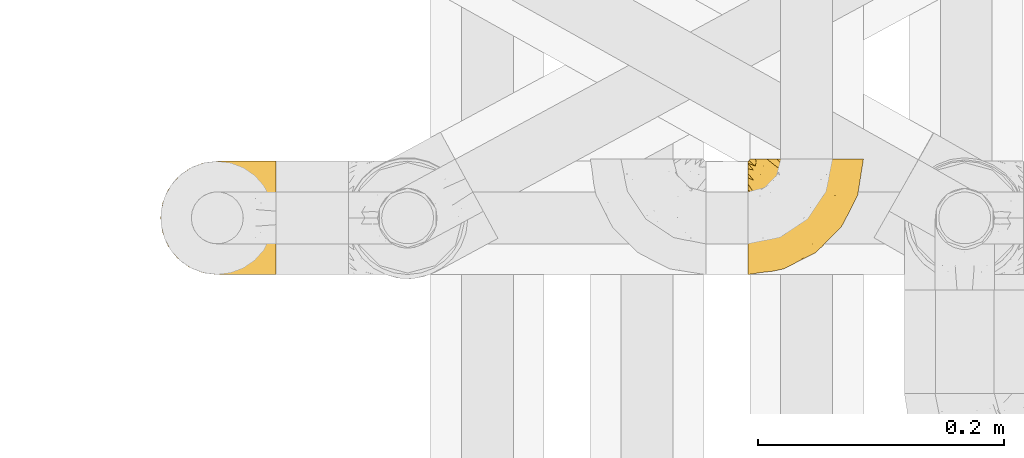
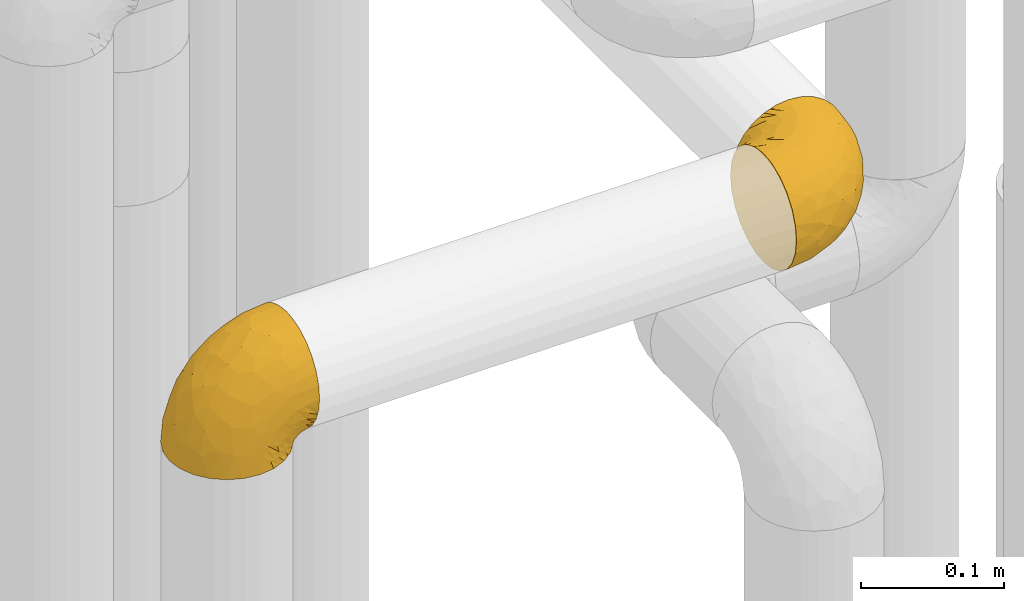
# One storey, part 158 of 827: 2 coverings.
"""IFC2X3 building model written with IfcOpenShell, lengths in millimetres."""

from ifc_helpers import new_model, entity, si_unit, converted_unit, derived_unit, direction, frame, origin, place, context, subcontext, project, spatial, faceted_brep, element, save


model = new_model("IFC2X3")

# Units and contexts
model_context = context("Model", 3, precision=0.01, world=origin(), true_north=direction((6.12303176911189e-17, 1.0)))
body_context = subcontext(model_context, "Body", "Model", "MODEL_VIEW")
ifc_project = project(units=[si_unit("LENGTHUNIT", "METRE", prefix="MILLI"), si_unit("AREAUNIT", "SQUARE_METRE"), si_unit("VOLUMEUNIT", "CUBIC_METRE"), converted_unit("PLANEANGLEUNIT", "DEGREE", entity("IfcRatioMeasure", 0.0174532925199433), si_unit("PLANEANGLEUNIT", "RADIAN"), dimensions=[0, 0, 0, 0, 0, 0, 0]), si_unit("MASSUNIT", "GRAM", prefix="KILO"), derived_unit("MASSDENSITYUNIT", [(si_unit("MASSUNIT", "GRAM", prefix="KILO"), 1), (si_unit("LENGTHUNIT", "METRE"), -3)]), derived_unit("MOMENTOFINERTIAUNIT", [(si_unit("LENGTHUNIT", "METRE"), 4)]), si_unit("TIMEUNIT", "SECOND"), si_unit("FREQUENCYUNIT", "HERTZ"), si_unit("THERMODYNAMICTEMPERATUREUNIT", "DEGREE_CELSIUS"), derived_unit("THERMALTRANSMITTANCEUNIT", [(si_unit("MASSUNIT", "GRAM", prefix="KILO"), 1), (si_unit("THERMODYNAMICTEMPERATUREUNIT", "KELVIN"), -1), (si_unit("TIMEUNIT", "SECOND"), -3)]), derived_unit("VOLUMETRICFLOWRATEUNIT", [(si_unit("LENGTHUNIT", "METRE"), 3), (si_unit("TIMEUNIT", "SECOND"), -1)]), derived_unit("MASSFLOWRATEUNIT", [(si_unit("MASSUNIT", "GRAM", prefix="KILO"), 1), (si_unit("TIMEUNIT", "SECOND"), -1)]), derived_unit("ROTATIONALFREQUENCYUNIT", [(si_unit("TIMEUNIT", "SECOND"), -1)]), si_unit("ELECTRICCURRENTUNIT", "AMPERE"), si_unit("ELECTRICVOLTAGEUNIT", "VOLT"), si_unit("POWERUNIT", "WATT"), si_unit("FORCEUNIT", "NEWTON", prefix="KILO"), si_unit("ILLUMINANCEUNIT", "LUX"), si_unit("LUMINOUSFLUXUNIT", "LUMEN"), si_unit("LUMINOUSINTENSITYUNIT", "CANDELA"), derived_unit("USERDEFINED", [(si_unit("MASSUNIT", "GRAM", prefix="KILO"), -1), (si_unit("LENGTHUNIT", "METRE"), -2), (si_unit("TIMEUNIT", "SECOND"), 3), (si_unit("LUMINOUSFLUXUNIT", "LUMEN"), 1)]), derived_unit("LINEARVELOCITYUNIT", [(si_unit("LENGTHUNIT", "METRE"), 1), (si_unit("TIMEUNIT", "SECOND"), -1)]), si_unit("PRESSUREUNIT", "PASCAL"), derived_unit("USERDEFINED", [(si_unit("LENGTHUNIT", "METRE"), -2), (si_unit("MASSUNIT", "GRAM", prefix="KILO"), 1), (si_unit("TIMEUNIT", "SECOND"), -2)]), derived_unit("LINEARFORCEUNIT", [(si_unit("MASSUNIT", "GRAM", prefix="KILO"), 1), (si_unit("LENGTHUNIT", "METRE"), 1), (si_unit("TIMEUNIT", "SECOND"), -2), (si_unit("LENGTHUNIT", "METRE"), -1)]), derived_unit("PLANARFORCEUNIT", [(si_unit("MASSUNIT", "GRAM", prefix="KILO"), 1), (si_unit("LENGTHUNIT", "METRE"), 1), (si_unit("TIMEUNIT", "SECOND"), -2), (si_unit("LENGTHUNIT", "METRE"), -2)])], contexts=[model_context])

# Site, building, storey
site_placement = place(None, origin())
site = spatial("IfcSite", under=ifc_project, at=site_placement, CompositionType="ELEMENT")
building_placement = place(site_placement, origin())
building = spatial("IfcBuilding", under=site, at=building_placement, CompositionType="ELEMENT")
storey_placement = place(building_placement, frame((0.0, 0.0, 28200.0)))
storey = spatial("IfcBuildingStorey", under=building, at=storey_placement, Name="08", CompositionType="ELEMENT", Elevation=28200.0)

# Coverings
covering_1_placement = place(storey_placement, frame((35550.49, 11508.39, 2952.2)))
element("IfcCovering", 1, at=covering_1_placement, inside=storey, Name=":ADSK_", ObjectType=":ADSK_", PredefinedType="INSULATION", context=body_context, shape_type="Brep", body=[
    faceted_brep([(59.89, 95.8, 92.84), (69.65, 95.8, 89.42), (78.41, 95.8, 83.91), (85.73, 95.8, 76.59), (91.23, 95.8, 67.83), (94.64, 95.8, 58.07), (95.8, 95.8, 47.8), (94.64, 95.8, 37.51), (91.22, 95.8, 27.74), (85.72, 95.8, 18.98), (78.4, 95.8, 11.67), (69.64, 95.8, 6.17), (59.87, 95.8, 2.75), (49.6, 95.8, 1.6), (45.46, 95.8, 2.06), (42.39, 95.8, 2.41), (39.31, 95.8, 2.75), (34.43, 95.8, 4.46), (29.55, 95.8, 6.17), (25.17, 95.8, 8.93), (20.79, 95.8, 11.68), (17.13, 95.8, 15.34), (13.47, 95.8, 19.0), (7.97, 95.8, 27.76), (6.26, 95.8, 32.64), (4.56, 95.8, 37.52), (3.4, 95.8, 47.8), (4.56, 95.8, 58.08), (6.27, 95.8, 62.96), (7.98, 95.8, 67.85), (13.49, 95.8, 76.61), (17.14, 95.8, 80.26), (20.8, 95.8, 83.92), (25.18, 95.8, 86.67), (29.56, 95.8, 89.42), (34.44, 95.8, 91.13), (39.33, 95.8, 92.84), (42.39, 95.8, 93.18), (45.46, 95.8, 93.53), (49.6, 95.8, 94.0), (1.6, 94.0, 47.8), (1.6, 92.42, 35.84), (1.6, 87.81, 24.7), (1.6, 84.13, 19.91), (1.6, 80.46, 15.13), (1.6, 75.68, 11.46), (1.6, 70.9, 7.78), (1.6, 65.32, 5.48), (1.6, 59.75, 3.17), (1.6, 56.14, 2.69), (1.6, 54.05, 2.42), (1.6, 51.97, 2.14), (1.6, 47.8, 1.6), (1.6, 35.84, 3.17), (1.6, 24.7, 7.78), (1.6, 15.13, 15.13), (1.6, 7.78, 24.7), (1.6, 3.17, 35.84), (1.6, 1.6, 47.8), (1.6, 3.17, 59.75), (1.6, 7.78, 70.9), (1.6, 15.13, 80.46), (1.6, 24.7, 87.81), (1.6, 35.84, 92.42), (1.6, 47.8, 94.0), (1.6, 51.97, 93.45), (1.6, 56.14, 92.9), (1.6, 59.75, 92.42), (1.6, 65.32, 90.11), (1.6, 70.9, 87.81), (1.6, 75.68, 84.13), (1.6, 80.46, 80.46), (1.6, 84.13, 75.68), (1.6, 87.81, 70.9), (1.6, 92.42, 59.75), (36.81, 15.84, 71.98), (23.28, 6.99, 63.6), (45.8, 14.39, 59.72), (30.71, 6.2, 47.8), (21.2, 4.26, 55.16), (12.96, 3.39, 47.8), (66.2, 31.2, 63.76), (54.52, 26.47, 72.22), (17.98, 11.44, 74.18), (36.69, 47.65, 92.52), (35.54, 61.85, 94.0), (31.65, 59.25, 94.0), (27.75, 56.65, 94.0), (23.86, 54.05, 94.0), (19.97, 51.45, 94.0), (22.8, 19.8, 82.14), (42.68, 26.22, 80.34), (33.22, 31.58, 87.52), (59.45, 38.36, 79.59), (71.51, 51.54, 78.25), (62.67, 51.6, 85.01), (54.51, 55.97, 90.25), (47.57, 62.88, 93.2), (48.82, 41.35, 87.23), (74.99, 82.24, 85.55), (18.7, 40.88, 93.0), (15.75, 29.0, 89.31), (91.18, 74.06, 61.31), (85.28, 54.53, 56.86), (82.58, 57.97, 68.34), (75.78, 43.81, 65.71), (74.99, 38.22, 56.99), (67.27, 38.33, 72.15), (87.38, 74.76, 70.34), (82.04, 76.85, 78.36), (94.0, 84.43, 47.8), (77.81, 40.42, 47.8), (67.39, 30.0, 47.8), (56.21, 78.67, 93.06), (48.86, 92.06, 94.0), (48.11, 88.32, 94.0), (47.57, 85.6, 94.0), (47.03, 82.88, 94.0), (46.49, 80.15, 94.0), (45.95, 77.43, 94.0), (65.79, 76.36, 89.88), (17.24, 50.91, 94.0), (14.52, 50.36, 94.0), (11.79, 49.82, 94.0), (9.07, 49.28, 94.0), (7.2, 48.91, 94.0), (5.33, 48.54, 94.0), (91.19, 66.68, 47.8), (43.34, 73.53, 94.0), (40.74, 69.64, 94.0), (38.14, 65.75, 94.0), (72.73, 66.13, 83.7), (56.97, 19.58, 47.8), (62.23, 24.64, 55.9), (84.5, 53.55, 47.8), (43.84, 12.89, 47.8), (12.05, 82.81, 81.75), (18.95, 81.22, 86.43), (13.02, 86.57, 79.8), (8.34, 92.75, 69.84), (14.63, 89.68, 79.5), (11.09, 72.26, 88.08), (13.66, 64.73, 91.6), (20.08, 62.45, 92.93), (9.62, 60.63, 92.43), (9.48, 56.91, 93.24), (16.1, 58.14, 93.36), (3.43, 93.7, 57.25), (26.63, 83.4, 89.41), (33.72, 75.54, 92.89), (34.77, 79.46, 92.66), (6.75, 82.28, 79.58), (13.32, 76.25, 86.51), (19.95, 90.18, 83.91), (27.05, 87.92, 88.76), (6.05, 86.94, 73.94), (8.67, 65.12, 90.94), (26.11, 71.71, 91.94), (29.3, 75.21, 91.98), (6.33, 78.6, 82.79), (39.92, 87.27, 93.16), (34.41, 86.1, 91.89), (2.87, 94.52, 47.8), (20.93, 66.23, 92.22), (21.12, 84.69, 86.29), (27.43, 91.08, 88.56), (7.54, 71.77, 87.72), (18.46, 76.21, 88.33), (23.88, 68.58, 92.18), (7.78, 89.94, 71.78), (26.09, 71.7, 3.66), (18.44, 76.22, 7.27), (18.94, 81.22, 9.17), (9.07, 49.28, 1.6), (5.33, 48.54, 1.6), (14.52, 50.36, 1.6), (11.79, 49.82, 1.6), (3.42, 93.7, 38.35), (7.77, 89.95, 23.83), (47.03, 82.88, 1.6), (47.57, 85.6, 1.6), (48.86, 92.06, 1.6), (48.11, 88.32, 1.6), (14.62, 89.68, 16.1), (27.03, 87.92, 6.84), (20.08, 62.45, 2.66), (20.92, 66.23, 3.37), (27.75, 56.65, 1.6), (31.65, 59.25, 1.6), (6.33, 78.6, 12.8), (9.62, 60.63, 3.16), (9.48, 56.91, 2.35), (8.34, 92.76, 25.77), (13.3, 76.25, 9.09), (6.75, 82.28, 16.02), (12.04, 82.81, 13.85), (23.86, 54.05, 1.6), (19.97, 51.45, 1.6), (16.1, 58.14, 2.23), (19.94, 90.18, 11.69), (21.1, 84.7, 9.31), (39.93, 87.25, 2.43), (33.68, 75.58, 2.71), (29.29, 75.2, 3.61), (26.62, 83.39, 6.18), (27.88, 90.73, 6.77), (34.76, 79.47, 2.93), (6.05, 86.94, 21.66), (38.14, 65.75, 1.6), (12.8, 86.75, 16.09), (34.42, 86.08, 3.7), (45.95, 77.43, 1.6), (43.34, 73.53, 1.6), (40.74, 69.64, 1.6), (13.66, 64.73, 3.99), (17.24, 50.91, 1.6), (8.67, 65.12, 4.65), (11.09, 72.26, 7.51), (35.54, 61.85, 1.6), (23.84, 68.61, 3.43), (6.03, 74.03, 9.46), (46.49, 80.15, 1.6), (34.53, 49.81, 2.4), (21.2, 4.26, 40.43), (23.82, 19.95, 13.57), (41.32, 30.61, 11.3), (47.63, 25.71, 18.65), (52.66, 22.43, 27.26), (36.82, 15.84, 23.61), (49.75, 60.69, 3.07), (19.08, 40.49, 2.69), (45.8, 14.39, 35.87), (23.28, 6.99, 31.99), (21.36, 29.56, 6.71), (17.98, 11.44, 21.41), (82.58, 57.98, 27.24), (91.17, 74.06, 34.26), (85.27, 54.52, 38.73), (73.89, 43.47, 26.97), (66.2, 31.2, 31.83), (62.43, 33.27, 23.4), (63.54, 64.26, 6.91), (58.46, 74.29, 3.4), (67.17, 80.41, 5.84), (76.73, 41.67, 35.73), (62.23, 24.64, 39.69), (81.54, 73.62, 17.6), (74.8, 78.98, 10.38), (75.84, 53.69, 20.6), (41.45, 42.86, 5.36), (88.21, 79.66, 24.84), (71.61, 58.41, 13.87), (56.24, 47.11, 9.06), (59.45, 38.37, 15.99)], [[[0, 1, 2, 3, 4, 5, 6, 7, 8, 9, 10, 11, 12, 13, 14, 15, 16, 17, 18, 19, 20, 21, 22, 23, 24, 25, 26, 27, 28, 29, 30, 31, 32, 33, 34, 35, 36, 37, 38, 39]], [[40, 41, 42, 43, 44, 45, 46, 47, 48, 49, 50, 51, 52, 53, 54, 55, 56, 57, 58, 59, 60, 61, 62, 63, 64, 65, 66, 67, 68, 69, 70, 71, 72, 73, 74]], [[75, 76, 77]], [[78, 79, 80]], [[77, 81, 82]], [[76, 75, 83]], [[84, 85, 86, 87, 88, 89]], [[90, 91, 92]], [[76, 60, 59]], [[93, 94, 95]], [[90, 62, 61]], [[83, 61, 60]], [[96, 97, 84]], [[98, 93, 95]], [[2, 1, 99]], [[100, 84, 89]], [[62, 101, 63]], [[4, 102, 5]], [[92, 84, 100]], [[103, 102, 104]], [[103, 105, 106]], [[93, 107, 94]], [[3, 108, 4]], [[92, 101, 90]], [[108, 3, 109]], [[102, 110, 5]], [[93, 82, 107]], [[102, 108, 104]], [[111, 106, 112]], [[109, 2, 99]], [[113, 39, 114, 115, 116, 117, 118, 119]], [[120, 0, 113]], [[100, 89, 121, 122, 123, 124, 125, 126, 64]], [[127, 102, 103]], [[97, 119, 128, 129, 130, 85]], [[99, 120, 131]], [[132, 133, 77]], [[59, 80, 79]], [[3, 2, 109]], [[98, 84, 92]], [[94, 109, 131]], [[120, 1, 0]], [[93, 91, 82]], [[104, 94, 105]], [[97, 113, 119]], [[95, 120, 96]], [[83, 90, 61]], [[91, 93, 98]], [[64, 63, 100]], [[100, 63, 101]], [[77, 76, 79]], [[133, 106, 81]], [[84, 97, 85]], [[113, 96, 120]], [[113, 97, 96]], [[39, 113, 0]], [[110, 102, 127]], [[110, 6, 5]], [[103, 111, 134, 127]], [[90, 75, 91]], [[82, 81, 107]], [[91, 75, 82]], [[77, 82, 75]], [[76, 83, 60]], [[90, 83, 75]], [[105, 107, 81]], [[94, 131, 95]], [[105, 94, 107]], [[109, 94, 104]], [[120, 95, 131]], [[98, 95, 96]], [[84, 98, 96]], [[98, 92, 91]], [[106, 105, 81]], [[103, 104, 105]], [[133, 132, 112]], [[103, 106, 111]], [[77, 78, 135, 132]], [[106, 133, 112]], [[77, 133, 81]], [[120, 99, 1]], [[109, 99, 131]], [[59, 58, 80]], [[59, 79, 76]], [[90, 101, 62]], [[100, 101, 92]], [[4, 108, 102]], [[109, 104, 108]], [[78, 77, 79]], [[136, 137, 138]], [[29, 139, 140]], [[141, 142, 143]], [[144, 145, 121]], [[146, 89, 88]], [[147, 139, 27]], [[148, 149, 150]], [[136, 151, 152]], [[147, 40, 74]], [[26, 147, 27]], [[153, 148, 154]], [[35, 116, 36]], [[155, 73, 151]], [[114, 39, 38, 37, 36, 116, 115]], [[146, 156, 144]], [[157, 85, 130]], [[158, 149, 148]], [[151, 159, 152]], [[117, 35, 160]], [[31, 153, 154]], [[155, 74, 73]], [[161, 128, 119]], [[66, 65, 64, 126, 125, 124, 123, 122, 67]], [[162, 147, 26]], [[29, 140, 30]], [[149, 129, 150]], [[139, 29, 28, 27]], [[68, 144, 69]], [[129, 128, 150]], [[163, 87, 86]], [[130, 129, 149]], [[122, 145, 67]], [[153, 164, 148]], [[161, 119, 160]], [[165, 32, 154]], [[150, 154, 148]], [[128, 161, 150]], [[32, 165, 33]], [[145, 144, 68]], [[89, 146, 144]], [[87, 163, 143]], [[166, 156, 142]], [[88, 87, 143]], [[161, 154, 150]], [[154, 32, 31]], [[31, 30, 153]], [[30, 140, 153]], [[164, 153, 140]], [[140, 137, 164]], [[158, 148, 164]], [[157, 130, 158]], [[164, 137, 158]], [[158, 137, 157]], [[167, 137, 136]], [[168, 85, 157]], [[152, 168, 167]], [[167, 168, 157]], [[163, 152, 141]], [[151, 73, 72]], [[152, 167, 136]], [[88, 142, 146]], [[144, 156, 69]], [[146, 142, 156]], [[70, 166, 71]], [[142, 141, 166]], [[70, 69, 156]], [[141, 159, 71]], [[159, 72, 71]], [[138, 137, 140]], [[155, 136, 169]], [[136, 155, 151]], [[74, 155, 169]], [[152, 159, 141]], [[151, 72, 159]], [[168, 152, 163]], [[137, 167, 157]], [[163, 86, 168]], [[85, 168, 86]], [[116, 35, 117]], [[130, 149, 158]], [[67, 145, 68]], [[121, 89, 144]], [[145, 122, 121]], [[40, 147, 162]], [[169, 147, 74]], [[160, 35, 34]], [[161, 160, 34]], [[160, 119, 118, 117]], [[139, 147, 169]], [[139, 169, 138]], [[161, 34, 33]], [[141, 143, 163]], [[88, 143, 142]], [[71, 166, 141]], [[156, 166, 70]], [[139, 138, 140]], [[169, 136, 138]], [[154, 161, 165]], [[161, 33, 165]], [[170, 171, 172]], [[173, 174, 52, 51, 50, 49, 48, 175, 176]], [[177, 178, 41]], [[179, 17, 180]], [[14, 13, 181, 182, 180, 16, 15]], [[183, 23, 22]], [[21, 20, 184]], [[185, 186, 187]], [[186, 188, 187]], [[43, 189, 44]], [[190, 191, 47]], [[25, 24, 23, 192]], [[193, 194, 195]], [[40, 162, 177]], [[196, 197, 198]], [[26, 25, 177]], [[199, 200, 183]], [[201, 17, 179]], [[47, 46, 190]], [[202, 203, 204]], [[203, 170, 172]], [[205, 206, 184]], [[207, 41, 178]], [[18, 17, 201]], [[16, 180, 17]], [[204, 203, 200]], [[208, 203, 202]], [[162, 26, 177]], [[48, 47, 191]], [[198, 197, 190]], [[199, 184, 204]], [[172, 195, 209]], [[210, 211, 212]], [[206, 212, 213]], [[205, 19, 210]], [[184, 206, 204]], [[210, 212, 206]], [[185, 196, 214]], [[190, 215, 191]], [[216, 45, 214]], [[186, 217, 193]], [[190, 216, 198]], [[199, 22, 21]], [[196, 185, 187]], [[199, 183, 22]], [[184, 199, 21]], [[199, 204, 200]], [[206, 202, 204]], [[172, 183, 200]], [[203, 208, 170]], [[170, 208, 218]], [[172, 200, 203]], [[218, 188, 219]], [[195, 171, 193]], [[217, 186, 185]], [[193, 219, 186]], [[193, 171, 219]], [[42, 207, 194]], [[217, 220, 189]], [[216, 190, 46]], [[214, 196, 198]], [[44, 220, 45]], [[214, 198, 216]], [[216, 46, 45]], [[214, 45, 220]], [[217, 189, 193]], [[43, 42, 194]], [[207, 195, 194]], [[209, 195, 178]], [[41, 207, 42]], [[195, 207, 178]], [[43, 194, 189]], [[193, 189, 194]], [[172, 171, 195]], [[171, 170, 219]], [[218, 219, 170]], [[188, 186, 219]], [[206, 213, 202]], [[208, 202, 213]], [[201, 210, 18]], [[215, 190, 197]], [[215, 175, 191]], [[175, 48, 191]], [[201, 179, 221, 211]], [[210, 201, 211]], [[25, 192, 177]], [[40, 177, 41]], [[178, 177, 192]], [[23, 183, 192]], [[209, 192, 183]], [[205, 20, 19]], [[19, 18, 210]], [[217, 185, 214]], [[189, 220, 44]], [[214, 220, 217]], [[192, 209, 178]], [[172, 209, 183]], [[206, 205, 210]], [[20, 205, 184]], [[222, 197, 196, 187, 188, 218]], [[57, 223, 80]], [[224, 225, 226]], [[226, 227, 228]], [[229, 218, 208, 213, 212, 211]], [[230, 52, 174, 173, 176, 175, 215, 197]], [[231, 232, 228]], [[231, 78, 223]], [[223, 57, 232]], [[224, 233, 225]], [[233, 54, 53]], [[234, 232, 56]], [[56, 55, 234]], [[234, 224, 228]], [[235, 236, 237]], [[224, 55, 54]], [[238, 239, 240]], [[52, 230, 53]], [[241, 242, 243]], [[239, 244, 245]], [[13, 12, 242]], [[236, 8, 7]], [[9, 246, 10]], [[10, 247, 11]], [[238, 248, 235]], [[222, 229, 249]], [[242, 211, 221, 179, 180, 182, 181, 13]], [[233, 53, 230]], [[111, 112, 244]], [[250, 8, 236]], [[247, 251, 241]], [[8, 250, 9]], [[127, 236, 110]], [[249, 229, 252]], [[247, 10, 246]], [[235, 246, 250]], [[236, 7, 110]], [[235, 244, 238]], [[237, 236, 127]], [[243, 11, 247]], [[252, 229, 241]], [[56, 232, 57]], [[222, 230, 197]], [[225, 249, 252]], [[249, 233, 230]], [[54, 233, 224]], [[231, 228, 227]], [[245, 132, 231]], [[249, 225, 233]], [[226, 225, 253]], [[235, 250, 236]], [[246, 9, 250]], [[251, 247, 246]], [[243, 247, 241]], [[248, 246, 235]], [[252, 251, 253]], [[229, 222, 218]], [[230, 222, 249]], [[7, 6, 110]], [[237, 127, 134, 111]], [[238, 244, 239]], [[224, 234, 55]], [[232, 234, 228]], [[242, 241, 229]], [[12, 11, 243]], [[211, 242, 229]], [[12, 243, 242]], [[80, 223, 78]], [[80, 58, 57]], [[231, 223, 232]], [[227, 240, 239]], [[224, 226, 228]], [[240, 226, 253]], [[227, 239, 245]], [[226, 240, 227]], [[251, 248, 253]], [[240, 253, 248]], [[244, 235, 237]], [[237, 111, 244]], [[132, 245, 112]], [[112, 245, 244]], [[135, 78, 231, 132]], [[227, 245, 231]], [[248, 238, 240]], [[246, 248, 251]], [[251, 252, 241]], [[225, 252, 253]]]),
])
covering_2_placement = place(storey_placement, frame((35072.24, 11508.41, 2950.4)))
element("IfcCovering", 2, at=covering_2_placement, inside=storey, Name=":ADSK_", ObjectType=":ADSK_", PredefinedType="INSULATION", context=body_context, shape_type="Brep", body=[
    faceted_brep([(95.8, 92.84, 59.88), (95.8, 89.42, 69.65), (95.8, 83.91, 78.41), (95.8, 76.59, 85.72), (95.8, 67.83, 91.22), (95.8, 58.07, 94.64), (95.8, 47.8, 95.8), (95.79, 37.51, 94.64), (95.79, 27.74, 91.22), (95.79, 18.98, 85.71), (95.79, 11.67, 78.39), (95.79, 6.17, 69.63), (95.79, 2.75, 59.87), (95.79, 1.6, 49.6), (95.79, 2.06, 45.45), (95.79, 2.41, 42.38), (95.79, 2.75, 39.31), (95.79, 4.46, 34.43), (95.79, 6.17, 29.54), (95.79, 8.93, 25.16), (95.79, 11.68, 20.78), (95.79, 15.34, 17.13), (95.79, 19.0, 13.47), (95.79, 27.76, 7.97), (95.79, 32.64, 6.26), (95.79, 37.52, 4.55), (95.8, 47.8, 3.4), (95.8, 58.08, 4.55), (95.8, 62.96, 6.26), (95.8, 67.85, 7.97), (95.8, 76.61, 13.48), (95.8, 80.26, 17.14), (95.8, 83.92, 20.8), (95.8, 86.67, 25.18), (95.8, 89.42, 29.56), (95.8, 91.13, 34.44), (95.8, 92.84, 39.32), (95.8, 93.18, 42.39), (95.8, 93.53, 45.45), (95.8, 94.0, 49.6), (94.0, 47.8, 1.6), (92.42, 35.84, 1.6), (87.8, 24.7, 1.6), (84.13, 19.91, 1.6), (80.46, 15.13, 1.6), (75.68, 11.46, 1.6), (70.89, 7.79, 1.6), (65.32, 5.48, 1.6), (59.75, 3.17, 1.6), (56.14, 2.7, 1.6), (54.05, 2.42, 1.6), (51.97, 2.15, 1.6), (47.79, 1.6, 1.6), (35.84, 3.17, 1.6), (24.69, 7.79, 1.6), (15.13, 15.13, 1.6), (7.78, 24.7, 1.6), (3.17, 35.84, 1.6), (1.6, 47.8, 1.6), (3.17, 59.76, 1.6), (7.79, 70.9, 1.6), (15.13, 80.47, 1.6), (24.7, 87.81, 1.6), (35.84, 92.42, 1.6), (47.8, 94.0, 1.6), (51.97, 93.45, 1.6), (56.14, 92.9, 1.6), (59.76, 92.42, 1.6), (65.33, 90.11, 1.6), (70.9, 87.81, 1.6), (75.68, 84.14, 1.6), (80.47, 80.46, 1.6), (84.14, 75.68, 1.6), (87.81, 70.9, 1.6), (92.42, 59.75, 1.6), (15.84, 71.99, 36.81), (6.99, 63.61, 23.28), (14.39, 59.73, 45.8), (6.21, 47.8, 30.7), (4.26, 55.17, 21.2), (3.39, 47.8, 12.96), (31.2, 63.76, 66.19), (26.47, 72.23, 54.51), (11.45, 74.18, 17.98), (47.66, 92.52, 36.69), (61.86, 94.0, 35.54), (59.26, 94.0, 31.64), (56.65, 94.0, 27.75), (54.05, 94.0, 23.86), (51.45, 94.0, 19.96), (19.8, 82.15, 22.8), (26.22, 80.34, 42.67), (31.58, 87.53, 33.21), (38.36, 79.59, 59.45), (51.54, 78.26, 71.5), (51.6, 85.01, 62.66), (55.97, 90.25, 54.5), (62.88, 93.2, 47.57), (41.35, 87.23, 48.81), (82.25, 85.55, 74.98), (40.88, 93.01, 18.7), (29.0, 89.31, 15.75), (74.06, 61.32, 91.17), (54.53, 56.86, 85.28), (57.98, 68.34, 82.58), (43.81, 65.71, 75.78), (38.22, 57.0, 74.98), (38.34, 72.15, 67.27), (74.76, 70.34, 87.38), (76.85, 78.36, 82.04), (84.43, 47.8, 94.0), (40.43, 47.8, 77.8), (30.01, 47.8, 67.38), (78.68, 93.06, 56.2), (92.06, 94.0, 48.85), (88.33, 94.0, 48.11), (85.6, 94.0, 47.57), (82.88, 94.0, 47.03), (80.15, 94.0, 46.48), (77.43, 94.0, 45.94), (76.37, 89.88, 65.78), (50.91, 94.0, 17.24), (50.37, 94.0, 14.51), (49.83, 94.0, 11.79), (49.28, 94.0, 9.07), (48.91, 94.0, 7.2), (48.54, 94.0, 5.33), (66.69, 47.8, 91.18), (73.54, 94.0, 43.34), (69.64, 94.0, 40.74), (65.75, 94.0, 38.14), (66.13, 83.7, 72.73), (19.59, 47.8, 56.96), (24.64, 55.91, 62.23), (53.56, 47.8, 84.49), (12.9, 47.8, 43.83), (82.81, 81.75, 12.05), (81.22, 86.43, 18.95), (86.57, 79.8, 13.02), (92.75, 69.84, 8.34), (89.69, 79.5, 14.63), (72.26, 88.08, 11.09), (64.73, 91.6, 13.66), (62.46, 92.93, 20.08), (60.64, 92.43, 9.61), (56.91, 93.24, 9.48), (58.15, 93.36, 16.1), (93.7, 57.25, 3.42), (83.4, 89.41, 26.63), (75.54, 92.9, 33.72), (79.46, 92.66, 34.77), (82.28, 79.58, 6.75), (76.25, 86.51, 13.31), (90.18, 83.91, 19.94), (87.92, 88.76, 27.05), (65.12, 90.94, 8.67), (71.71, 91.94, 26.11), (75.21, 91.98, 29.3), (78.6, 82.79, 6.32), (87.28, 93.16, 39.92), (86.94, 73.94, 6.04), (86.1, 91.89, 34.4), (94.52, 47.8, 2.87), (66.23, 92.22, 20.92), (84.7, 86.29, 21.11), (91.09, 88.56, 27.43), (71.77, 87.72, 7.54), (76.22, 88.33, 18.45), (68.59, 92.18, 23.88), (89.94, 71.78, 7.77), (76.22, 7.27, 18.43), (81.22, 9.17, 18.93), (71.7, 3.66, 26.08), (49.28, 1.6, 9.07), (48.54, 1.6, 5.33), (50.36, 1.6, 14.51), (49.82, 1.6, 11.79), (93.7, 38.35, 3.42), (89.95, 23.84, 7.76), (82.87, 1.6, 47.03), (85.6, 1.6, 47.57), (92.06, 1.6, 48.85), (88.32, 1.6, 48.11), (89.68, 16.1, 14.62), (87.92, 6.84, 27.03), (62.45, 2.67, 20.08), (66.23, 3.37, 20.92), (56.65, 1.6, 27.75), (59.25, 1.6, 31.64), (78.6, 12.8, 6.33), (60.63, 3.17, 9.61), (56.91, 2.35, 9.48), (92.76, 25.77, 8.33), (76.25, 9.09, 13.3), (82.28, 16.02, 6.74), (82.81, 13.85, 12.04), (54.05, 1.6, 23.86), (51.45, 1.6, 19.96), (58.14, 2.24, 16.1), (90.18, 11.69, 19.93), (84.69, 9.31, 21.1), (87.25, 2.43, 39.92), (75.57, 2.71, 33.68), (75.2, 3.61, 29.28), (83.39, 6.19, 26.62), (90.73, 6.77, 27.87), (79.47, 2.94, 34.75), (86.94, 21.66, 6.04), (65.74, 1.6, 38.14), (86.75, 16.09, 12.79), (86.08, 3.7, 34.41), (77.42, 1.6, 45.94), (73.53, 1.6, 43.34), (69.64, 1.6, 40.74), (64.73, 3.99, 13.66), (50.9, 1.6, 17.24), (65.12, 4.65, 8.67), (72.26, 7.51, 11.09), (61.85, 1.6, 35.54), (68.61, 3.43, 23.83), (74.03, 9.47, 6.03), (80.15, 1.6, 46.48), (49.81, 2.4, 34.52), (4.26, 40.43, 21.2), (19.95, 13.57, 23.82), (30.61, 11.31, 41.32), (25.71, 18.65, 47.62), (22.43, 27.26, 52.66), (15.84, 23.61, 36.81), (60.69, 3.07, 49.75), (40.49, 2.69, 19.07), (14.39, 35.87, 45.8), (6.99, 31.99, 23.28), (29.56, 6.71, 21.35), (11.44, 21.42, 17.98), (57.98, 27.24, 82.57), (74.06, 34.27, 91.17), (54.52, 38.73, 85.27), (43.47, 26.97, 73.89), (31.2, 31.83, 66.19), (33.27, 23.41, 62.43), (64.26, 6.91, 63.53), (74.29, 3.4, 58.45), (80.41, 5.84, 67.16), (41.67, 35.73, 76.72), (24.64, 39.69, 62.22), (73.62, 17.6, 81.54), (78.98, 10.39, 74.8), (53.69, 20.6, 75.83), (42.86, 5.36, 41.45), (79.66, 24.84, 88.2), (58.41, 13.87, 71.6), (47.11, 9.06, 56.23), (38.37, 16.0, 59.44)], [[[0, 1, 2, 3, 4, 5, 6, 7, 8, 9, 10, 11, 12, 13, 14, 15, 16, 17, 18, 19, 20, 21, 22, 23, 24, 25, 26, 27, 28, 29, 30, 31, 32, 33, 34, 35, 36, 37, 38, 39]], [[40, 41, 42, 43, 44, 45, 46, 47, 48, 49, 50, 51, 52, 53, 54, 55, 56, 57, 58, 59, 60, 61, 62, 63, 64, 65, 66, 67, 68, 69, 70, 71, 72, 73, 74]], [[75, 76, 77]], [[78, 79, 80]], [[77, 81, 82]], [[76, 75, 83]], [[84, 85, 86, 87, 88, 89]], [[90, 91, 92]], [[76, 60, 59]], [[93, 94, 95]], [[90, 62, 61]], [[83, 61, 60]], [[96, 97, 84]], [[98, 93, 95]], [[2, 1, 99]], [[100, 84, 89]], [[62, 101, 63]], [[4, 102, 5]], [[92, 84, 100]], [[103, 102, 104]], [[103, 105, 106]], [[93, 107, 94]], [[3, 108, 4]], [[92, 101, 90]], [[108, 3, 109]], [[102, 110, 5]], [[93, 82, 107]], [[102, 108, 104]], [[111, 106, 112]], [[109, 2, 99]], [[113, 39, 114, 115, 116, 117, 118, 119]], [[120, 0, 113]], [[100, 89, 121, 122, 123, 124, 125, 126, 64]], [[127, 102, 103]], [[97, 119, 128, 129, 130, 85]], [[99, 120, 131]], [[132, 133, 77]], [[59, 80, 79]], [[3, 2, 109]], [[98, 84, 92]], [[94, 109, 131]], [[120, 1, 0]], [[93, 91, 82]], [[104, 94, 105]], [[97, 113, 119]], [[95, 120, 96]], [[83, 90, 61]], [[91, 93, 98]], [[64, 63, 100]], [[100, 63, 101]], [[77, 76, 79]], [[133, 106, 81]], [[84, 97, 85]], [[113, 96, 120]], [[113, 97, 96]], [[39, 113, 0]], [[110, 102, 127]], [[110, 6, 5]], [[103, 111, 134, 127]], [[90, 75, 91]], [[82, 81, 107]], [[91, 75, 82]], [[77, 82, 75]], [[76, 83, 60]], [[90, 83, 75]], [[105, 107, 81]], [[94, 131, 95]], [[105, 94, 107]], [[109, 94, 104]], [[120, 95, 131]], [[98, 95, 96]], [[84, 98, 96]], [[98, 92, 91]], [[106, 105, 81]], [[103, 104, 105]], [[112, 106, 133]], [[103, 106, 111]], [[112, 133, 132]], [[81, 77, 133]], [[77, 78, 135, 132]], [[120, 99, 1]], [[109, 99, 131]], [[59, 58, 80]], [[59, 79, 76]], [[90, 101, 62]], [[100, 101, 92]], [[4, 108, 102]], [[109, 104, 108]], [[78, 77, 79]], [[136, 137, 138]], [[29, 139, 140]], [[141, 142, 143]], [[144, 145, 121]], [[146, 89, 88]], [[147, 139, 27]], [[148, 149, 150]], [[136, 151, 152]], [[147, 40, 74]], [[26, 147, 27]], [[153, 148, 154]], [[35, 116, 36]], [[73, 72, 151]], [[114, 39, 38, 37, 36, 116, 115]], [[146, 155, 144]], [[156, 85, 130]], [[157, 149, 148]], [[151, 158, 152]], [[117, 35, 159]], [[31, 153, 154]], [[160, 74, 73]], [[161, 128, 119]], [[66, 65, 64, 126, 125, 124, 123, 122, 67]], [[162, 147, 26]], [[29, 140, 30]], [[149, 129, 150]], [[139, 29, 28, 27]], [[68, 144, 69]], [[129, 128, 150]], [[163, 87, 86]], [[130, 129, 149]], [[122, 145, 67]], [[153, 164, 148]], [[161, 119, 159]], [[165, 32, 154]], [[150, 154, 148]], [[128, 161, 150]], [[32, 165, 33]], [[145, 144, 68]], [[89, 146, 144]], [[87, 163, 143]], [[166, 155, 142]], [[88, 87, 143]], [[161, 154, 150]], [[154, 32, 31]], [[31, 30, 153]], [[30, 140, 153]], [[164, 153, 140]], [[140, 137, 164]], [[157, 148, 164]], [[156, 130, 157]], [[164, 137, 157]], [[157, 137, 156]], [[167, 137, 136]], [[168, 85, 156]], [[152, 168, 167]], [[167, 168, 156]], [[163, 152, 141]], [[71, 158, 72]], [[152, 167, 136]], [[88, 142, 146]], [[144, 155, 69]], [[146, 142, 155]], [[70, 166, 71]], [[142, 141, 166]], [[70, 69, 155]], [[141, 158, 71]], [[160, 73, 151]], [[138, 137, 140]], [[160, 136, 169]], [[136, 160, 151]], [[74, 160, 169]], [[152, 158, 141]], [[151, 72, 158]], [[168, 152, 163]], [[137, 167, 156]], [[163, 86, 168]], [[85, 168, 86]], [[116, 35, 117]], [[130, 149, 157]], [[67, 145, 68]], [[121, 89, 144]], [[145, 122, 121]], [[40, 147, 162]], [[169, 147, 74]], [[159, 35, 34]], [[161, 159, 34]], [[159, 119, 118, 117]], [[139, 147, 169]], [[139, 169, 138]], [[161, 34, 33]], [[141, 143, 163]], [[88, 143, 142]], [[71, 166, 141]], [[155, 166, 70]], [[139, 138, 140]], [[169, 136, 138]], [[154, 161, 165]], [[161, 33, 165]], [[170, 171, 172]], [[173, 174, 52, 51, 50, 49, 48, 175, 176]], [[177, 178, 41]], [[179, 17, 180]], [[14, 13, 181, 182, 180, 16, 15]], [[183, 23, 22]], [[21, 20, 184]], [[185, 186, 187]], [[186, 188, 187]], [[43, 189, 44]], [[190, 191, 47]], [[25, 24, 23, 192]], [[193, 194, 195]], [[40, 162, 177]], [[196, 197, 198]], [[26, 25, 177]], [[199, 200, 183]], [[201, 17, 179]], [[47, 46, 190]], [[202, 203, 204]], [[203, 172, 171]], [[205, 206, 184]], [[207, 41, 178]], [[18, 17, 201]], [[16, 180, 17]], [[204, 203, 200]], [[208, 203, 202]], [[162, 26, 177]], [[48, 47, 191]], [[198, 197, 190]], [[199, 184, 204]], [[171, 195, 209]], [[210, 211, 212]], [[206, 212, 213]], [[205, 19, 210]], [[184, 206, 204]], [[210, 212, 206]], [[185, 196, 214]], [[190, 215, 191]], [[216, 45, 214]], [[186, 217, 193]], [[190, 216, 198]], [[21, 184, 199]], [[196, 185, 187]], [[21, 199, 22]], [[200, 199, 204]], [[183, 22, 199]], [[206, 202, 204]], [[171, 183, 200]], [[203, 208, 172]], [[172, 208, 218]], [[171, 200, 203]], [[218, 188, 219]], [[195, 170, 193]], [[217, 186, 185]], [[193, 219, 186]], [[193, 170, 219]], [[207, 194, 42]], [[217, 220, 189]], [[216, 190, 46]], [[214, 196, 198]], [[44, 220, 45]], [[214, 198, 216]], [[216, 46, 45]], [[214, 45, 220]], [[42, 194, 43]], [[189, 193, 217]], [[207, 195, 194]], [[209, 195, 178]], [[41, 207, 42]], [[195, 207, 178]], [[43, 194, 189]], [[193, 189, 194]], [[171, 170, 195]], [[170, 172, 219]], [[218, 219, 172]], [[188, 186, 219]], [[206, 213, 202]], [[208, 202, 213]], [[201, 210, 18]], [[215, 190, 197]], [[215, 175, 191]], [[175, 48, 191]], [[201, 179, 221, 211]], [[210, 201, 211]], [[25, 192, 177]], [[40, 177, 41]], [[183, 209, 192]], [[183, 192, 23]], [[192, 178, 177]], [[205, 20, 19]], [[19, 18, 210]], [[217, 185, 214]], [[189, 220, 44]], [[214, 220, 217]], [[192, 209, 178]], [[171, 209, 183]], [[206, 205, 210]], [[20, 205, 184]], [[222, 197, 196, 187, 188, 218]], [[57, 223, 80]], [[224, 225, 226]], [[226, 227, 228]], [[229, 218, 208, 213, 212, 211]], [[230, 52, 174, 173, 176, 175, 215, 197]], [[231, 232, 228]], [[231, 78, 223]], [[223, 57, 232]], [[224, 233, 225]], [[233, 54, 53]], [[234, 232, 56]], [[56, 55, 234]], [[234, 224, 228]], [[235, 236, 237]], [[224, 55, 54]], [[238, 239, 240]], [[52, 230, 53]], [[241, 242, 243]], [[239, 244, 245]], [[13, 12, 242]], [[236, 8, 7]], [[9, 246, 10]], [[10, 247, 11]], [[238, 248, 235]], [[222, 229, 249]], [[242, 211, 221, 179, 180, 182, 181, 13]], [[233, 53, 230]], [[111, 112, 244]], [[250, 8, 236]], [[247, 251, 241]], [[8, 250, 9]], [[127, 236, 110]], [[249, 229, 252]], [[247, 10, 246]], [[235, 246, 250]], [[236, 7, 110]], [[235, 244, 238]], [[237, 236, 127]], [[243, 11, 247]], [[252, 229, 241]], [[56, 232, 57]], [[222, 230, 197]], [[225, 249, 252]], [[249, 233, 230]], [[54, 233, 224]], [[231, 228, 227]], [[245, 132, 231]], [[249, 225, 233]], [[226, 225, 253]], [[235, 250, 236]], [[246, 9, 250]], [[251, 247, 246]], [[243, 247, 241]], [[248, 246, 235]], [[252, 251, 253]], [[229, 222, 218]], [[230, 222, 249]], [[7, 6, 110]], [[237, 127, 134, 111]], [[238, 244, 239]], [[224, 234, 55]], [[232, 234, 228]], [[242, 241, 229]], [[12, 11, 243]], [[211, 242, 229]], [[12, 243, 242]], [[80, 223, 78]], [[80, 58, 57]], [[231, 223, 232]], [[227, 240, 239]], [[224, 226, 228]], [[240, 226, 253]], [[227, 239, 245]], [[226, 240, 227]], [[251, 248, 253]], [[240, 253, 248]], [[244, 235, 237]], [[237, 111, 244]], [[132, 245, 112]], [[112, 245, 244]], [[135, 78, 231, 132]], [[227, 245, 231]], [[248, 238, 240]], [[246, 248, 251]], [[251, 252, 241]], [[225, 252, 253]]]),
])

save(model, "model.ifc")
